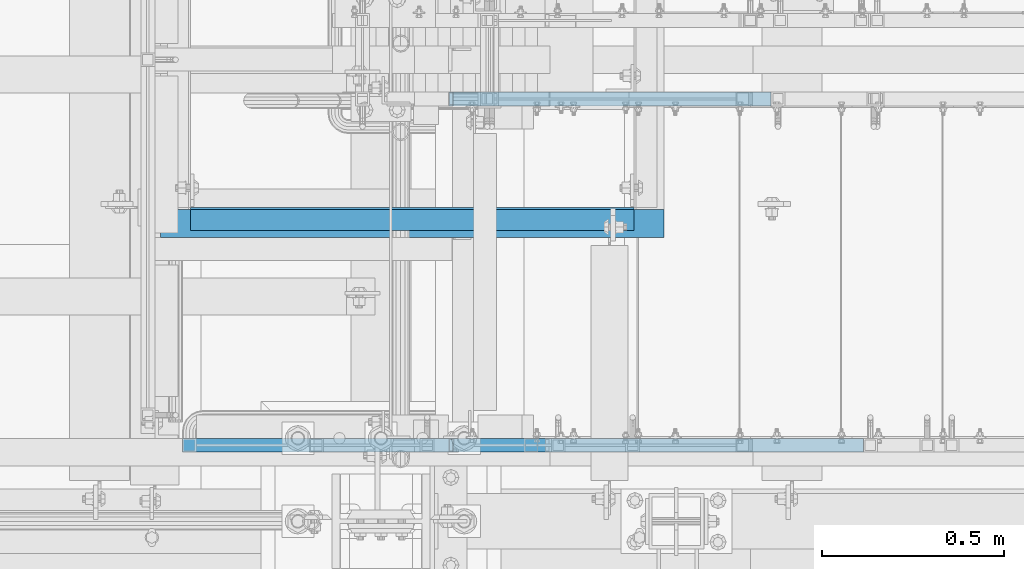
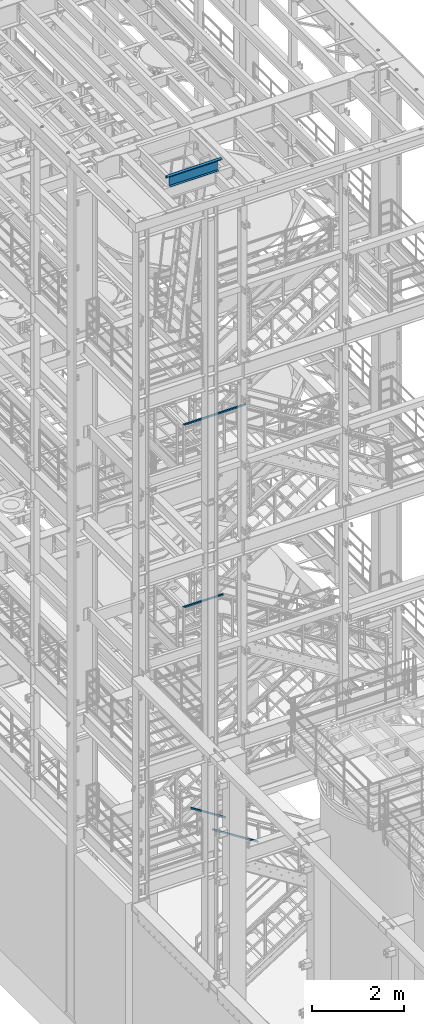
# One storey, part 935 of 1876: 4 beams, 2 members, 5 elements without a shape of their own.
"""IFC2X3 building model written with IfcOpenShell, lengths in millimetres."""

from ifc_helpers import new_model, si_unit, frame, origin_with_axes, place, context, subcontext, project, spatial, faceted_brep, material, type_object, element, aggregate, save


model = new_model("IFC2X3")

# Units and contexts
model_context = context("Model", 3, precision=1e-05, world=origin_with_axes())
body_context = subcontext(model_context, "Body", "Model", "MODEL_VIEW")
ifc_project = project(units=[si_unit("LENGTHUNIT", "METRE", prefix="MILLI"), si_unit("AREAUNIT", "SQUARE_METRE"), si_unit("VOLUMEUNIT", "CUBIC_METRE"), si_unit("MASSUNIT", "GRAM", prefix="KILO"), si_unit("TIMEUNIT", "SECOND"), si_unit("PLANEANGLEUNIT", "RADIAN"), si_unit("SOLIDANGLEUNIT", "STERADIAN"), si_unit("THERMODYNAMICTEMPERATUREUNIT", "DEGREE_CELSIUS"), si_unit("LUMINOUSINTENSITYUNIT", "LUMEN")], contexts=[model_context])

# Site, building, storey
site_placement = place(None, origin_with_axes())
site = spatial("IfcSite", under=ifc_project, at=site_placement, CompositionType="ELEMENT")
building_placement = place(site_placement, origin_with_axes())
building = spatial("IfcBuilding", under=site, at=building_placement, Name="Undefined", CompositionType="ELEMENT")
storey_placement = place(building_placement, origin_with_axes())
storey = spatial("IfcBuildingStorey", under=building, at=storey_placement, Name="Undefined", CompositionType="ELEMENT", Elevation=0.0)

# Assembly, beam
assembly_1_placement = place(storey_placement, origin_with_axes())
assembly_1 = element("IfcElementAssembly", 1, at=assembly_1_placement, inside=storey, Name="RAIL", AssemblyPlace="NOTDEFINED", PredefinedType="RIGID_FRAME")
ifc_material_1 = material()
beam_type_1 = type_object("IfcBeamType", Name="HSS1-1/2X1-1/2X1/8", PredefinedType="NOTDEFINED")
beam_1_placement = place(assembly_1_placement, frame((1200.15000079767, -6902.45000114554, 11807.82499896), z_axis=(0.0, 0.0, -1.0), x_axis=(1.0, 0.0, 0.0)))
beam_1 = element("IfcBeam", 2, at=beam_1_placement, type_object=beam_type_1, material=ifc_material_1, Name="RAIL", ObjectType="HSS1-1/2X1-1/2X1/8", context=body_context, shape_type="Brep", body=[
    faceted_brep([(-15.875, 15.8749981318675, -15.875), (-15.875, -15.8750000000011, -15.875), (988.764430263744, -15.8749992829999, -15.8749992829999), (988.764430263744, 15.8749992829999, -15.8749992829999), (15.875, -15.8750000000011, 15.875), (979.780698715306, -15.8749992829999, 15.8749992829999), (15.875, 15.8749981318675, 15.875), (979.780698715306, 15.8749992829999, 15.8749992829999), (-19.049999234363, 19.0499992349996, -19.0499992350001), (19.0500000000002, 19.0499992349996, 19.0499992350001), (978.882325533469, 19.0499992349996, 19.0499992349996), (989.662803445581, 19.0499992349996, -19.0499992349996), (19.0500000000002, -19.0499992349996, 19.0499992350001), (978.882325533469, -19.0499992349996, 19.0499992349996), (-19.049999234363, -19.0499992349996, -19.0499992350001), (989.662803445581, -19.0499992349996, -19.0499992349996)], [[[0, 1, 2, 3]], [[1, 4, 5, 2]], [[4, 6, 7, 5]], [[6, 0, 3, 7]], [[8, 9, 10, 11]], [[9, 12, 13, 10]], [[12, 14, 15, 13]], [[14, 8, 11, 15]], [[13, 15, 11, 10], [5, 7, 3, 2]], [[14, 12, 9, 8], [6, 4, 1, 0]]]),
])
aggregate(assembly_1, [beam_1])

assembly_2_placement = place(storey_placement, origin_with_axes())
assembly_2 = element("IfcElementAssembly", 3, at=assembly_2_placement, inside=storey, Name="RAIL", AssemblyPlace="NOTDEFINED", PredefinedType="RIGID_FRAME")
beam_2_placement = place(assembly_2_placement, frame((1181.10016558343, -6902.45000114331, 16636.1768516545), z_axis=(0.0, 0.0, -1.0), x_axis=(1.0, 0.0, 0.0)))
beam_2 = element("IfcBeam", 4, at=beam_2_placement, type_object=beam_type_1, material=ifc_material_1, Name="RAIL", ObjectType="HSS1-1/2X1-1/2X1/8", context=body_context, shape_type="Brep", body=[
    faceted_brep([(3.17499995199978, 15.8749992829999, -15.8749992829999), (3.17499995199978, -15.8749992829999, -15.8749992829999), (1566.61892920636, -15.8749992829999, -15.8749992823032), (1566.61892920636, 15.8749992829999, -15.8749992823032), (34.9249985179995, -15.8749992829999, 15.8749992829999), (1557.58107938778, -15.8749992829999, 15.8749992836929), (34.9249985179995, 15.8749992829999, 15.8749992829999), (1557.58107938778, 15.8749992829999, 15.8749992836929), (0.0, 19.0499992349996, -19.0499992350001), (38.0999984699993, 19.0499992349996, 19.0499992350001), (1556.67729437877, 19.0499992349996, 19.0499992356927), (1567.52271421537, 19.0499992349996, -19.049999234303), (38.0999984699993, -19.0499992349996, 19.0499992350001), (1556.67729437877, -19.0499992349996, 19.0499992356927), (0.0, -19.0499992349996, -19.0499992350001), (1567.52271421537, -19.0499992349996, -19.049999234303)], [[[0, 1, 2, 3]], [[1, 4, 5, 2]], [[4, 6, 7, 5]], [[6, 0, 3, 7]], [[8, 9, 10, 11]], [[9, 12, 13, 10]], [[12, 14, 15, 13]], [[14, 8, 11, 15]], [[13, 15, 11, 10], [5, 7, 3, 2]], [[14, 12, 9, 8], [6, 4, 1, 0]]]),
])
aggregate(assembly_2, [beam_2])

# Assembly, member
assembly_3_placement = place(storey_placement, origin_with_axes())
assembly_3 = element("IfcElementAssembly", 5, at=assembly_3_placement, inside=storey, Name="RAIL", AssemblyPlace="NOTDEFINED", PredefinedType="RIGID_FRAME")
member_type = type_object("IfcMemberType", Name="HSS1-1/2X1-1/2X1/8", PredefinedType="NOTDEFINED")
member_1_placement = place(assembly_3_placement, frame((2819.40000459023, -5949.95000114554, 5093.62562726338), z_axis=(0.535697420207059, 0.0, 0.844410015326383), x_axis=(-0.844410015326383, 0.0, 0.535697420207059)))
member_1 = element("IfcMember", 6, at=member_1_placement, type_object=member_type, material=ifc_material_1, Name="RAIL", ObjectType="HSS1-1/2X1-1/2X1/8", context=body_context, shape_type="Brep", body=[
    faceted_brep([(12.4889602027924, 15.8749992829999, -15.8749992829981), (12.4889602027924, -15.8749992829999, -15.8749992829981), (1060.49489956603, -15.8749992829999, -15.8749992832891), (1060.49489956603, 15.8749992829999, -15.8749992832891), (32.6312986338025, -15.8749992829999, 15.8749992830109), (1069.71648921363, -15.8749992829999, 15.8749992827152), (32.6312986338025, 15.8749992829999, 15.8749992830109), (1069.71648921363, 15.8749992829999, 15.8749992827152), (10.4747262991696, 19.0499992349996, -19.0499992349991), (34.6455325374254, 19.0499992349996, 19.049999235012), (1070.6386482061, 19.0499992349996, 19.0499992347159), (1059.57274057356, 19.0499992349996, -19.0499992352898), (34.6455325374254, -19.0499992349996, 19.049999235012), (1070.6386482061, -19.0499992349996, 19.0499992347159), (10.4747262991696, -19.0499992349996, -19.0499992349991), (1059.57274057356, -19.0499992349996, -19.0499992352898)], [[[0, 1, 2, 3]], [[1, 4, 5, 2]], [[4, 6, 7, 5]], [[6, 0, 3, 7]], [[8, 9, 10, 11]], [[9, 12, 13, 10]], [[12, 14, 15, 13]], [[14, 8, 11, 15]], [[13, 15, 11, 10], [5, 7, 3, 2]], [[14, 12, 9, 8], [6, 4, 1, 0]]]),
])
aggregate(assembly_3, [member_1])

assembly_4_placement = place(storey_placement, origin_with_axes())
assembly_4 = element("IfcElementAssembly", 7, at=assembly_4_placement, inside=storey, Name="RAIL", AssemblyPlace="NOTDEFINED", PredefinedType="RIGID_FRAME")
member_2_placement = place(assembly_4_placement, frame((3073.40000611472, -6902.45000114554, 4942.01191138263), z_axis=(0.535697420207059, 0.0, 0.844410015326383), x_axis=(-0.844410015326383, 0.0, 0.535697420207059)))
member_2 = element("IfcMember", 8, at=member_2_placement, type_object=member_type, material=ifc_material_1, Name="RAIL", ObjectType="HSS1-1/2X1-1/2X1/8", context=body_context, shape_type="Brep", body=[
    faceted_brep([(12.4889602027924, 15.8749992829999, -15.8749992829981), (12.4889602027924, -15.8749992829999, -15.8749992829981), (1361.2966385892, -15.8749992829999, -15.8749992833682), (1361.2966385892, 15.8749992829999, -15.8749992833682), (32.6312986338025, -15.8749992829999, 15.8749992830109), (1370.5182282368, -15.8749992829999, 15.8749992826351), (32.6312986338025, 15.8749992829999, 15.8749992830109), (1370.5182282368, 15.8749992829999, 15.8749992826351), (10.4747262991696, 19.0499992349996, -19.0499992349991), (34.6455325374254, 19.0499992349996, 19.049999235012), (1371.44038722927, 19.0499992349996, 19.0499992346358), (1360.37447959673, 19.0499992349996, -19.0499992353689), (34.6455325374254, -19.0499992349996, 19.049999235012), (1371.44038722927, -19.0499992349996, 19.0499992346358), (10.4747262991696, -19.0499992349996, -19.0499992349991), (1360.37447959673, -19.0499992349996, -19.0499992353689)], [[[0, 1, 2, 3]], [[1, 4, 5, 2]], [[4, 6, 7, 5]], [[6, 0, 3, 7]], [[8, 9, 10, 11]], [[9, 12, 13, 10]], [[12, 14, 15, 13]], [[14, 8, 11, 15]], [[13, 15, 11, 10], [5, 7, 3, 2]], [[14, 12, 9, 8], [6, 4, 1, 0]]]),
])
aggregate(assembly_4, [member_2])

# Assembly, beams
assembly_5_placement = place(storey_placement, origin_with_axes())
assembly_5 = element("IfcElementAssembly", 9, at=assembly_5_placement, inside=storey, Name="BENT_PLATE", AssemblyPlace="NOTDEFINED", PredefinedType="RIGID_FRAME")
ifc_material_2 = material(Name="STEEL/A36")
beam_type_2 = type_object("IfcBeamType", Name="L3X3X1/4", PredefinedType="NOTDEFINED")
beam_3_placement = place(assembly_5_placement, frame((1120.775, -6292.84999847412, 22831.424987793), z_axis=(0.0, -1.0, 0.0), x_axis=(1.0, 0.0, 0.0)))
beam_3 = element("IfcBeam", 10, at=beam_3_placement, type_object=beam_type_2, material=ifc_material_2, Name="ANGLE", ObjectType="L3X3X1/4", context=body_context, shape_type="Brep", body=[
    faceted_brep([(0.0, 38.1000000000004, -38.1), (0.0, 38.1000000000004, 38.1), (1384.3, 38.0999999999985, 38.1000000000004), (1384.3, 38.0999999999985, -38.1000000000004), (0.0, 31.75, 38.1000000000004), (1384.3, 31.75, 38.1000000000004), (0.0, 31.75, -31.75), (1384.3, 31.75, -31.75), (0.0, -38.1000000000004, -31.75), (1384.3, -38.0999999999985, -31.75), (0.0, -38.1000000000004, -38.1), (1384.3, -38.0999999999985, -38.1000000000004)], [[[0, 1, 2, 3]], [[1, 4, 5, 2]], [[4, 6, 7, 5]], [[6, 8, 9, 7]], [[8, 10, 11, 9]], [[10, 0, 3, 11]], [[5, 7, 9, 11, 3, 2]], [[10, 8, 6, 4, 1, 0]]]),
])
beam_type_3 = type_object("IfcBeamType", PredefinedType="NOTDEFINED")
beam_4_placement = place(assembly_5_placement, frame((1812.925, -6311.90000000002, 22567.9), z_axis=(-1.0, 0.0, 0.0), x_axis=(0.0, 1.0, 0.0)))
beam_4 = element("IfcBeam", 11, at=beam_4_placement, type_object=beam_type_3, material=ifc_material_2, Name="BENT_PLATE", context=body_context, shape_type="Brep", body=[
    faceted_brep([(0.0, -3.17499999999927, -609.6), (0.0, -3.17499999999927, 609.6), (0.0, 3.17499999999927, 609.6), (0.0, 3.17499999999927, -609.6), (63.5000000000182, 3.17499999999927, 609.6), (63.5000000000182, 3.17499999999927, -609.6), (57.1500000000178, -3.17499999999927, -609.6), (57.1500000000178, -3.17499999999927, 609.6), (63.5000000000182, -301.624987792951, 609.6), (63.5000000000182, -301.624987792951, -609.6), (57.1500000000178, -301.624987792951, 609.6), (57.1500000000178, -301.624987792951, -609.6)], [[[0, 1, 2, 3]], [[3, 2, 4, 5]], [[1, 0, 6, 7]], [[5, 4, 8, 9]], [[4, 2, 1, 7, 10, 8]], [[7, 6, 11, 10]], [[6, 0, 3, 5, 9, 11]], [[10, 11, 9, 8]]]),
])
aggregate(assembly_5, [beam_3, beam_4])

save(model, "model.ifc")
